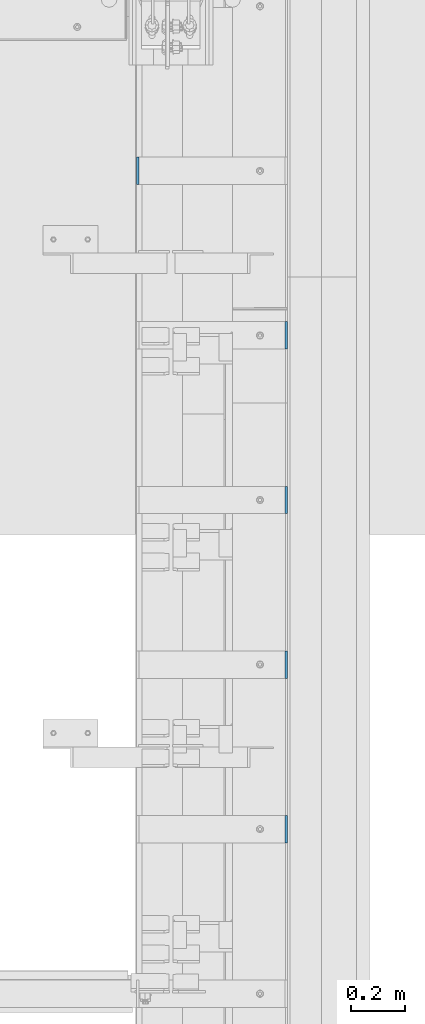
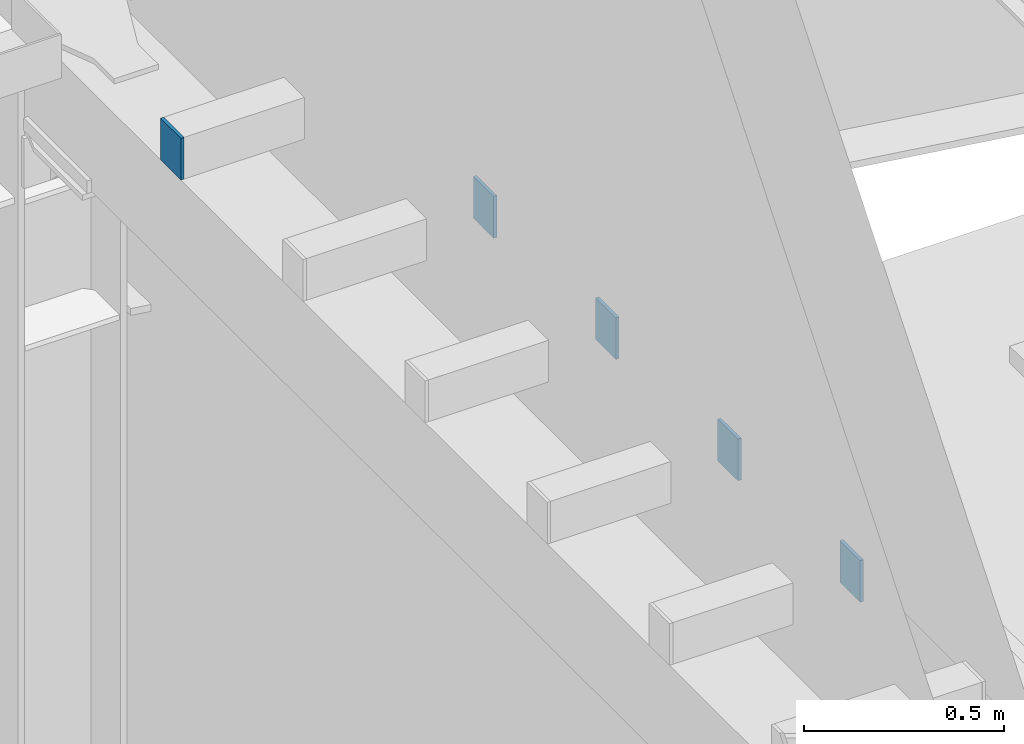
# One storey, part 463 of 1179: 5 columns, 5 elements without a shape of their own.
"""IFC2X3 building model written with IfcOpenShell, lengths in millimetres."""

import ifcopenshell
import ifcopenshell.guid

model = None  # the IFC model being written
_history = None  # IfcOwnerHistory: only IFC2X3 demands one
_inside = {}  # id of a spatial element -> (the spatial element, [elements in it])
_under = {}  # id of a project, library or spatial element -> (it, [spatial elements below it])
_declared = {}  # id of a project -> (the project, [libraries it declares])
_typed = {}  # id of a type object -> (the type object, [elements of that type])
_made_of = {}  # id of a material, layer set ... -> (it, [elements and type objects made of it])


def new_model(schema):
    """Start an empty IFC model of exactly this schema.

    Asked for "IFC4X3", IfcOpenShell would pick the latest addendum, in which some entities
    have other attributes; the version numbers below select the first issue.
    IFC2X3 requires an IfcOwnerHistory on every rooted entity: one is made here for all.
    """
    global model, _history
    if schema == "IFC4X3":
        model = ifcopenshell.file(schema_version=(4, 3, 0, 0))
    else:
        model = ifcopenshell.file(schema=schema)
    _inside.clear()
    _under.clear()
    _declared.clear()
    _typed.clear()
    _made_of.clear()
    _history = None
    if model.schema == "IFC2X3":
        org = make("IfcOrganization", Name="unknown")
        user = make(
            "IfcPersonAndOrganization",
            ThePerson=make("IfcPerson", FamilyName="unknown"),
            TheOrganization=org,
        )
        app = make(
            "IfcApplication",
            ApplicationDeveloper=org,
            Version="unknown",
            ApplicationFullName="unknown",
            ApplicationIdentifier="unknown",
        )
        _history = make(
            "IfcOwnerHistory",
            OwningUser=user,
            OwningApplication=app,
            ChangeAction="ADDED",
            CreationDate=0,
        )
    return model


def make(cls, **values):
    """One entity of the class cls with the attributes given. An attribute that is None is left unset."""
    return model.create_entity(
        cls, **{name: value for name, value in values.items() if value is not None}
    )


def rooted(cls, **values):
    """An entity with a GlobalId (a new one), such as an element, a storey or a relation."""
    return make(cls, GlobalId=ifcopenshell.guid.new(), OwnerHistory=_history, **values)


def si_unit(unit_type, name, prefix=None):
    """IfcSIUnit, for example si_unit("LENGTHUNIT", "METRE", prefix="MILLI")."""
    return make("IfcSIUnit", UnitType=unit_type, Prefix=prefix, Name=name)


def assignment(units):
    """IfcUnitAssignment: the units of a project."""
    return None if units is None else make("IfcUnitAssignment", Units=units)


def point(xyz):
    """IfcCartesianPoint."""
    return None if xyz is None else make("IfcCartesianPoint", Coordinates=xyz)


def direction(xyz):
    """IfcDirection."""
    return None if xyz is None else make("IfcDirection", DirectionRatios=xyz)


def frame(location, z_axis=None, x_axis=None):
    """IfcAxis2Placement3D, a coordinate frame: its origin and axes. An axis left out is left unset."""
    return make(
        "IfcAxis2Placement3D",
        Location=point(location),
        Axis=direction(z_axis),
        RefDirection=direction(x_axis),
    )


def origin_with_axes():
    """The frame at (0, 0, 0) with the z axis (0, 0, 1) and the x axis (1, 0, 0) written out."""
    return frame((0.0, 0.0, 0.0), z_axis=(0.0, 0.0, 1.0), x_axis=(1.0, 0.0, 0.0))


def place(relative_to, where):
    """IfcLocalPlacement: puts the frame where relative to a parent placement (None: the world)."""
    return make(
        "IfcLocalPlacement", PlacementRelTo=relative_to, RelativePlacement=where
    )


def context(
    kind, dimensions, precision=None, world=None, true_north=None, identifier=None
):
    """IfcGeometricRepresentationContext, for example the 3D "Model" context."""
    return make(
        "IfcGeometricRepresentationContext",
        ContextIdentifier=identifier,
        ContextType=kind,
        CoordinateSpaceDimension=dimensions,
        Precision=precision,
        WorldCoordinateSystem=world,
        TrueNorth=true_north,
    )


def subcontext(parent, identifier, kind, view, scale=None):
    """IfcGeometricRepresentationSubContext, for example "Body" below "Model"."""
    return make(
        "IfcGeometricRepresentationSubContext",
        ContextIdentifier=identifier,
        ContextType=kind,
        ParentContext=parent,
        TargetScale=scale,
        TargetView=view,
    )


def project(units=None, contexts=None):
    """IfcProject with its units and contexts."""
    return rooted(
        "IfcProject",
        Name="project",
        RepresentationContexts=contexts,
        UnitsInContext=assignment(units),
    )


def spatial(cls, under=None, at=None, **own):
    """A site, building, storey or space (cls), placed at a placement, below another one or the project."""
    s = rooted(cls, ObjectPlacement=at, **own)
    if under is not None:
        _under.setdefault(under.id(), (under, []))[1].append(s)
    return s


def faces_of(points, faces, orient=None, outer=None):
    """IfcFace entities. A face is a list of loops; a loop is a list of indices into points, from 0.

    orient and outer hold one flag for each loop. By default every Orientation is true, the
    first loop of a face is its IfcFaceOuterBound and the others are IfcFaceBound.
    """
    made = []
    for i, loops in enumerate(faces):
        bounds = []
        for j, loop in enumerate(loops):
            is_outer = j == 0 if outer is None else outer[i][j]
            bounds.append(
                make(
                    "IfcFaceOuterBound" if is_outer else "IfcFaceBound",
                    Bound=make("IfcPolyLoop", Polygon=[points[k] for k in loop]),
                    Orientation=True if orient is None else orient[i][j],
                )
            )
        made.append(make("IfcFace", Bounds=bounds))
    return made


def faceted_brep(points, faces, orient=None, outer=None, voids=None):
    """IfcFacetedBrep: a solid bounded by flat faces; with voids (closed shells), ...WithVoids."""
    shared = [point(p) for p in points]
    hull = make("IfcClosedShell", CfsFaces=faces_of(shared, faces, orient, outer))
    if voids is None:
        return make("IfcFacetedBrep", Outer=hull)
    return make(
        "IfcFacetedBrepWithVoids",
        Outer=hull,
        Voids=[
            make(cls, CfsFaces=faces_of(shared, fs, o, b)) for cls, fs, o, b in voids
        ],
    )


def shape(context_of_items, identifier, shape_type, items):
    """IfcShapeRepresentation: the items that make up one representation, for example the "Body"."""
    return make(
        "IfcShapeRepresentation",
        ContextOfItems=context_of_items,
        RepresentationIdentifier=identifier,
        RepresentationType=shape_type,
        Items=items,
    )


def material(Name=None, Category=None):
    """IfcMaterial."""
    return make("IfcMaterial", Name=Name, Category=Category)


def made_of(thing, what):
    """Note that an element or type object is made of a material, layer set ...; save() writes the relation."""
    if what is not None:
        _made_of.setdefault(what.id(), (what, []))[1].append(thing)
    return thing


def type_object(cls, material=None, **own):
    """A type object (cls), such as IfcWallType, which elements share."""
    return made_of(rooted(cls, **own), material)


def element(
    cls,
    number,
    at=None,
    inside=None,
    cuts=None,
    type_object=None,
    material=None,
    context=None,
    identifier="Body",
    shape_type=None,
    held_by="IfcProductDefinitionShape",
    body=None,
    shapes=None,
    **own,
):
    """One element of the class cls, such as IfcWall. Its Tag is "e" and its number.

    at: its placement. inside: the storey or other place that contains it. cuts: it is an
    opening in that element (IfcRelVoidsElement). A single representation is given by context,
    identifier, shape_type and body (its items); several are given by shapes. held_by: the class
    of the entity that holds the representations. save() writes the other relations.
    """
    e = rooted(cls, Tag="e%d" % number, ObjectPlacement=at, **own)
    if body is not None:
        shapes = [shape(context, identifier, shape_type, body)]
    if shapes is not None:
        e.Representation = make(held_by, Representations=shapes)
    if inside is not None:
        _inside.setdefault(inside.id(), (inside, []))[1].append(e)
    if cuts is not None:
        rooted(
            "IfcRelVoidsElement", RelatingBuildingElement=cuts, RelatedOpeningElement=e
        )
    if type_object is not None:
        _typed.setdefault(type_object.id(), (type_object, []))[1].append(e)
    return made_of(e, material)


def aggregate(whole, parts):
    """IfcRelAggregates: a whole, such as a stair, and the parts it consists of."""
    return rooted("IfcRelAggregates", RelatingObject=whole, RelatedObjects=parts)


def save(model, path):
    """Write the relations noted so far, then the file.

    IfcRelAggregates (storeys below a building ...), IfcRelContainedInSpatialStructure (elements
    in a storey), IfcRelDefinesByType, IfcRelAssociatesMaterial and IfcRelDeclares: one each for
    every whole, place, type object, material and project.
    """
    for whole, parts in _under.values():
        aggregate(whole, parts)
    for where, things in _inside.values():
        rooted(
            "IfcRelContainedInSpatialStructure",
            RelatedElements=things,
            RelatingStructure=where,
        )
    for kind, things in _typed.values():
        rooted("IfcRelDefinesByType", RelatedObjects=things, RelatingType=kind)
    for what, things in _made_of.values():
        rooted("IfcRelAssociatesMaterial", RelatedObjects=things, RelatingMaterial=what)
    for by, libraries in _declared.values():
        rooted("IfcRelDeclares", RelatingContext=by, RelatedDefinitions=libraries)
    model.write(path)


model = new_model("IFC2X3")

# Units and contexts
model_context = context("Model", 3, precision=1e-05, world=origin_with_axes())
body_context = subcontext(model_context, "Body", "Model", "MODEL_VIEW")
ifc_project = project(units=[si_unit("LENGTHUNIT", "METRE", prefix="MILLI"), si_unit("AREAUNIT", "SQUARE_METRE"), si_unit("VOLUMEUNIT", "CUBIC_METRE"), si_unit("MASSUNIT", "GRAM", prefix="KILO"), si_unit("TIMEUNIT", "SECOND"), si_unit("PLANEANGLEUNIT", "RADIAN"), si_unit("SOLIDANGLEUNIT", "STERADIAN"), si_unit("THERMODYNAMICTEMPERATUREUNIT", "DEGREE_CELSIUS"), si_unit("LUMINOUSINTENSITYUNIT", "LUMEN")], contexts=[model_context])

# Site, building, storey
site_placement = place(None, origin_with_axes())
site = spatial("IfcSite", under=ifc_project, at=site_placement, CompositionType="ELEMENT")
building_placement = place(site_placement, origin_with_axes())
building = spatial("IfcBuilding", under=site, at=building_placement, Name="Undefined", CompositionType="ELEMENT")
storey_placement = place(building_placement, origin_with_axes())
storey = spatial("IfcBuildingStorey", under=building, at=storey_placement, Name="Undefined", CompositionType="ELEMENT", Elevation=0.0)

# Assembly, column
assembly_1_placement = place(storey_placement, origin_with_axes())
assembly_1 = element("IfcElementAssembly", 1, at=assembly_1_placement, inside=storey, Name="BEAM", AssemblyPlace="NOTDEFINED", PredefinedType="RIGID_FRAME")
ifc_material = material(Name="STEEL/A36")
column_type = type_object("IfcColumnType", PredefinedType="NOTDEFINED")
column_1_placement = place(assembly_1_placement, frame((24185.5625, 26187.4, 8013.69999998781), z_axis=(0.0, -1.0, 0.0), x_axis=(0.0, 0.0, 1.0)))
column_1 = element("IfcColumn", 2, at=column_1_placement, type_object=column_type, material=ifc_material, Name="PLATE", context=body_context, shape_type="Brep", body=[
    faceted_brep([(0.0, 4.76249999999982, -50.7999999999993), (0.0, 4.76249999999982, 50.7999999999993), (127.000000000371, 4.76249999928405, 50.8000000000002), (127.000000000371, 4.76249999928405, -50.8000000000002), (0.0, -4.76249999999982, 50.7999999999993), (127.0, -4.76250000000073, 50.7999999999993), (0.0, -4.76249999999982, -50.7999999999993), (127.0, -4.76250000000073, -50.7999999999993)], [[[0, 1, 2, 3]], [[1, 4, 5, 2]], [[4, 6, 7, 5]], [[6, 0, 3, 7]], [[5, 7, 3, 2]], [[6, 4, 1, 0]]]),
])
aggregate(assembly_1, [column_1])

assembly_2_placement = place(storey_placement, origin_with_axes())
assembly_2 = element("IfcElementAssembly", 3, at=assembly_2_placement, inside=storey, Name="BEAM", AssemblyPlace="NOTDEFINED", PredefinedType="RIGID_FRAME")
column_2_placement = place(assembly_2_placement, frame((24734.8375, 25577.8, 8013.69999998781), z_axis=(0.0, 1.0, 0.0), x_axis=(0.0, 0.0, 1.0)))
column_2 = element("IfcColumn", 4, at=column_2_placement, type_object=column_type, material=ifc_material, Name="PLATE", context=body_context, shape_type="Brep", body=[
    faceted_brep([(0.0, 4.76249999999982, -50.7999999999993), (0.0, 4.76249999999982, 50.7999999999993), (127.000000000371, 4.76249999928405, 50.8000000000002), (127.000000000371, 4.76249999928405, -50.8000000000002), (0.0, -4.76249999999982, 50.7999999999993), (127.0, -4.76250000000073, 50.7999999999993), (0.0, -4.76249999999982, -50.7999999999993), (127.0, -4.76250000000073, -50.7999999999993)], [[[0, 1, 2, 3]], [[1, 4, 5, 2]], [[4, 6, 7, 5]], [[6, 0, 3, 7]], [[5, 7, 3, 2]], [[6, 4, 1, 0]]]),
])
aggregate(assembly_2, [column_2])

assembly_3_placement = place(storey_placement, origin_with_axes())
assembly_3 = element("IfcElementAssembly", 5, at=assembly_3_placement, inside=storey, Name="BEAM", AssemblyPlace="NOTDEFINED", PredefinedType="RIGID_FRAME")
column_3_placement = place(assembly_3_placement, frame((24734.8375, 24968.2, 8013.69999998781), z_axis=(0.0, 1.0, 0.0), x_axis=(0.0, 0.0, 1.0)))
column_3 = element("IfcColumn", 6, at=column_3_placement, type_object=column_type, material=ifc_material, Name="PLATE", context=body_context, shape_type="Brep", body=[
    faceted_brep([(0.0, 4.76249999999982, -50.7999999999993), (0.0, 4.76249999999982, 50.7999999999993), (127.000000000371, 4.76249999928405, 50.8000000000002), (127.000000000371, 4.76249999928405, -50.8000000000002), (0.0, -4.76249999999982, 50.7999999999993), (127.0, -4.76250000000073, 50.7999999999993), (0.0, -4.76249999999982, -50.7999999999993), (127.0, -4.76250000000073, -50.7999999999993)], [[[0, 1, 2, 3]], [[1, 4, 5, 2]], [[4, 6, 7, 5]], [[6, 0, 3, 7]], [[5, 7, 3, 2]], [[6, 4, 1, 0]]]),
])
aggregate(assembly_3, [column_3])

assembly_4_placement = place(storey_placement, origin_with_axes())
assembly_4 = element("IfcElementAssembly", 7, at=assembly_4_placement, inside=storey, Name="BEAM", AssemblyPlace="NOTDEFINED", PredefinedType="RIGID_FRAME")
column_4_placement = place(assembly_4_placement, frame((24734.8375, 24358.6, 8013.69999998781), z_axis=(0.0, 1.0, 0.0), x_axis=(0.0, 0.0, 1.0)))
column_4 = element("IfcColumn", 8, at=column_4_placement, type_object=column_type, material=ifc_material, Name="PLATE", context=body_context, shape_type="Brep", body=[
    faceted_brep([(0.0, 4.76249999999982, -50.7999999999993), (0.0, 4.76249999999982, 50.7999999999993), (127.000000000371, 4.76249999928405, 50.8000000000002), (127.000000000371, 4.76249999928405, -50.8000000000002), (0.0, -4.76249999999982, 50.7999999999993), (127.0, -4.76250000000073, 50.7999999999993), (0.0, -4.76249999999982, -50.7999999999993), (127.0, -4.76250000000073, -50.7999999999993)], [[[0, 1, 2, 3]], [[1, 4, 5, 2]], [[4, 6, 7, 5]], [[6, 0, 3, 7]], [[5, 7, 3, 2]], [[6, 4, 1, 0]]]),
])
aggregate(assembly_4, [column_4])

assembly_5_placement = place(storey_placement, origin_with_axes())
assembly_5 = element("IfcElementAssembly", 9, at=assembly_5_placement, inside=storey, Name="BEAM", AssemblyPlace="NOTDEFINED", PredefinedType="RIGID_FRAME")
column_5_placement = place(assembly_5_placement, frame((24734.8375, 23749.0, 8013.69999998781), z_axis=(0.0, 1.0, 0.0), x_axis=(0.0, 0.0, 1.0)))
column_5 = element("IfcColumn", 10, at=column_5_placement, type_object=column_type, material=ifc_material, Name="PLATE", context=body_context, shape_type="Brep", body=[
    faceted_brep([(0.0, 4.76249999999982, -50.7999999999993), (0.0, 4.76249999999982, 50.7999999999993), (127.000000000371, 4.76249999928405, 50.8000000000002), (127.000000000371, 4.76249999928405, -50.8000000000002), (0.0, -4.76249999999982, 50.7999999999993), (127.0, -4.76250000000073, 50.7999999999993), (0.0, -4.76249999999982, -50.7999999999993), (127.0, -4.76250000000073, -50.7999999999993)], [[[0, 1, 2, 3]], [[1, 4, 5, 2]], [[4, 6, 7, 5]], [[6, 0, 3, 7]], [[5, 7, 3, 2]], [[6, 4, 1, 0]]]),
])
aggregate(assembly_5, [column_5])

save(model, "model.ifc")
